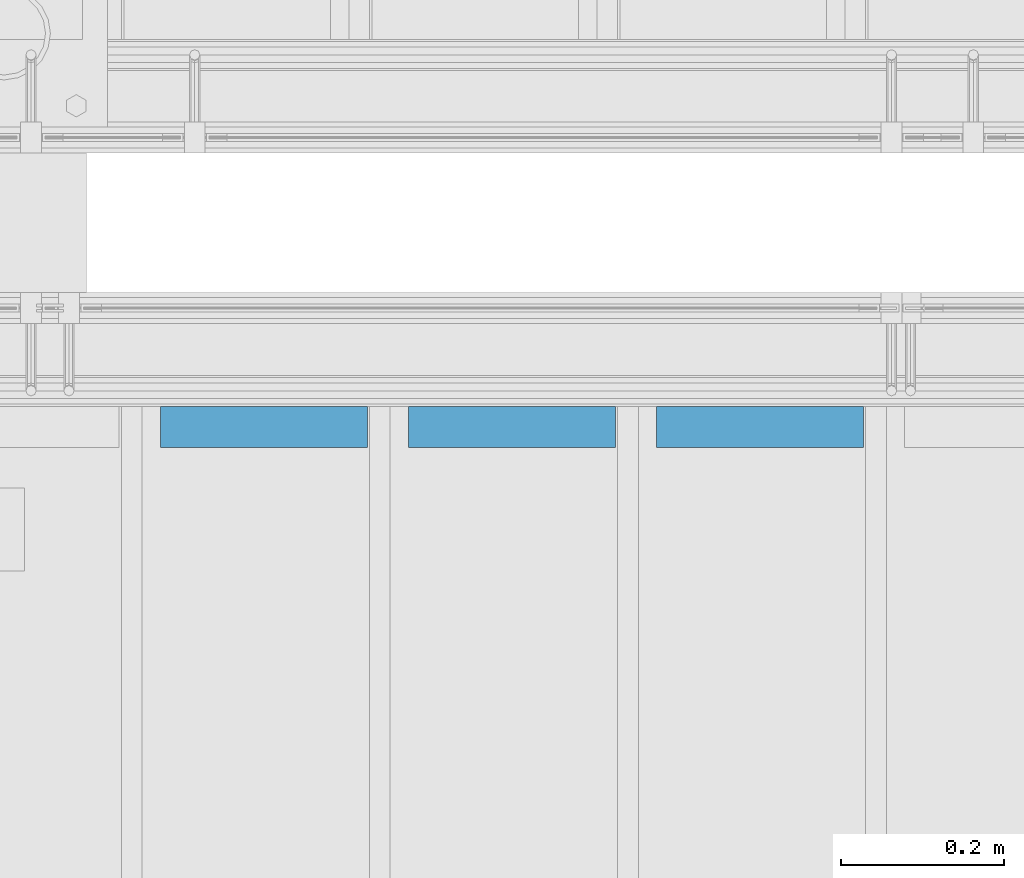
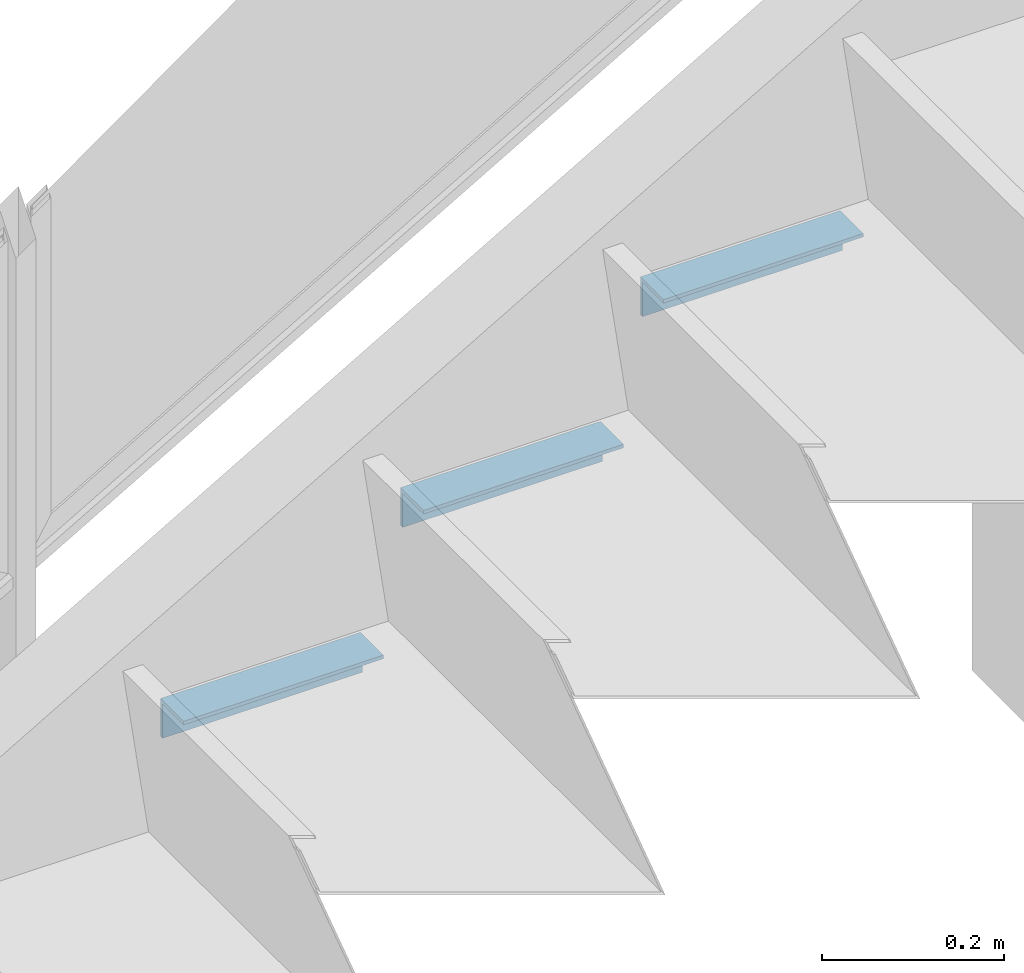
# One storey, part 916 of 1179: 3 beams, 1 element without a shape of its own.
"""IFC2X3 building model written with IfcOpenShell, lengths in millimetres."""

from ifc_helpers import new_model, si_unit, frame, origin_with_axes, place, context, subcontext, project, spatial, faceted_brep, material, type_object, element, aggregate, save


model = new_model("IFC2X3")

# Units and contexts
model_context = context("Model", 3, precision=1e-05, world=origin_with_axes())
body_context = subcontext(model_context, "Body", "Model", "MODEL_VIEW")
ifc_project = project(units=[si_unit("LENGTHUNIT", "METRE", prefix="MILLI"), si_unit("AREAUNIT", "SQUARE_METRE"), si_unit("VOLUMEUNIT", "CUBIC_METRE"), si_unit("MASSUNIT", "GRAM", prefix="KILO"), si_unit("TIMEUNIT", "SECOND"), si_unit("PLANEANGLEUNIT", "RADIAN"), si_unit("SOLIDANGLEUNIT", "STERADIAN"), si_unit("THERMODYNAMICTEMPERATUREUNIT", "DEGREE_CELSIUS"), si_unit("LUMINOUSINTENSITYUNIT", "LUMEN")], contexts=[model_context])

# Site, building, storey
site_placement = place(None, origin_with_axes())
site = spatial("IfcSite", under=ifc_project, at=site_placement, CompositionType="ELEMENT")
building_placement = place(site_placement, origin_with_axes())
building = spatial("IfcBuilding", under=site, at=building_placement, Name="Undefined", CompositionType="ELEMENT")
storey_placement = place(building_placement, origin_with_axes())
storey = spatial("IfcBuildingStorey", under=building, at=storey_placement, Name="Undefined", CompositionType="ELEMENT", Elevation=0.0)

# Assembly, beams
assembly_placement = place(storey_placement, origin_with_axes())
assembly = element("IfcElementAssembly", 1, at=assembly_placement, inside=storey, Name="STAIR", AssemblyPlace="NOTDEFINED", PredefinedType="RIGID_FRAME")
ifc_material = material(Name="STEEL/A36")
beam_type = type_object("IfcBeamType", Name="L2X2X3/16", PredefinedType="NOTDEFINED")
beam_1_placement = place(assembly_placement, frame((21377.6678271597, 39325.5499999974, 1156.55988296315), z_axis=(0.0, -1.0, 0.0), x_axis=(1.0, 0.0, 0.0)))
beam_1 = element("IfcBeam", 2, at=beam_1_placement, type_object=beam_type, material=ifc_material, Name="ANGLE", ObjectType="L2X2X3/16", context=body_context, shape_type="Brep", body=[
    faceted_brep([(0.0, 25.3999999999996, -25.4000000000015), (0.0, 25.3999999999996, 25.4000000000015), (254.0, 25.3999999999996, 25.4000000000001), (254.0, 25.3999999999996, -25.4000000000001), (0.0, 20.6374999999998, 25.4000000000015), (254.0, 20.6374999999998, 25.4000000000001), (0.0, 20.6374999999998, -20.6374999999971), (254.0, 20.6374999999998, -20.6374999999998), (0.0, -25.3999999999996, -20.6374999999971), (254.0, -25.3999999999996, -20.6374999999998), (0.0, -25.3999999999996, -25.4000000000015), (254.0, -25.3999999999996, -25.4000000000001)], [[[0, 1, 2, 3]], [[1, 4, 5, 2]], [[4, 6, 7, 5]], [[6, 8, 9, 7]], [[8, 10, 11, 9]], [[10, 0, 3, 11]], [[5, 7, 9, 11, 3, 2]], [[10, 8, 6, 4, 1, 0]]]),
])
beam_2_placement = place(assembly_placement, frame((21072.8678271329, 39325.5499999986, 980.082799683951), z_axis=(0.0, -1.0, 0.0), x_axis=(1.0, 0.0, 0.0)))
beam_2 = element("IfcBeam", 3, at=beam_2_placement, type_object=beam_type, material=ifc_material, Name="ANGLE", ObjectType="L2X2X3/16", context=body_context, shape_type="Brep", body=[
    faceted_brep([(0.0, 25.3999999999996, -25.4000000000015), (0.0, 25.3999999999996, 25.4000000000015), (254.0, 25.3999999999996, 25.4000000000001), (254.0, 25.3999999999996, -25.4000000000001), (0.0, 20.6374999999998, 25.4000000000015), (254.0, 20.6374999999998, 25.4000000000001), (0.0, 20.6374999999998, -20.6374999999971), (254.0, 20.6374999999998, -20.6374999999998), (0.0, -25.3999999999996, -20.6374999999971), (254.0, -25.3999999999996, -20.6374999999998), (0.0, -25.3999999999996, -25.4000000000015), (254.0, -25.3999999999996, -25.4000000000001)], [[[0, 1, 2, 3]], [[1, 4, 5, 2]], [[4, 6, 7, 5]], [[6, 8, 9, 7]], [[8, 10, 11, 9]], [[10, 0, 3, 11]], [[5, 7, 9, 11, 3, 2]], [[10, 8, 6, 4, 1, 0]]]),
])
beam_3_placement = place(assembly_placement, frame((20768.0678271062, 39325.5499999999, 803.605716404752), z_axis=(0.0, -1.0, 0.0), x_axis=(1.0, 0.0, 0.0)))
beam_3 = element("IfcBeam", 4, at=beam_3_placement, type_object=beam_type, material=ifc_material, Name="ANGLE", ObjectType="L2X2X3/16", context=body_context, shape_type="Brep", body=[
    faceted_brep([(0.0, 25.3999999999996, -25.4000000000015), (0.0, 25.3999999999996, 25.4000000000015), (254.0, 25.3999999999996, 25.4000000000001), (254.0, 25.3999999999996, -25.4000000000001), (0.0, 20.6374999999998, 25.4000000000015), (254.0, 20.6374999999998, 25.4000000000001), (0.0, 20.6374999999998, -20.6374999999971), (254.0, 20.6374999999998, -20.6374999999998), (0.0, -25.3999999999996, -20.6374999999971), (254.0, -25.3999999999996, -20.6374999999998), (0.0, -25.3999999999996, -25.4000000000015), (254.0, -25.3999999999996, -25.4000000000001)], [[[0, 1, 2, 3]], [[1, 4, 5, 2]], [[4, 6, 7, 5]], [[6, 8, 9, 7]], [[8, 10, 11, 9]], [[10, 0, 3, 11]], [[5, 7, 9, 11, 3, 2]], [[10, 8, 6, 4, 1, 0]]]),
])
aggregate(assembly, [beam_1, beam_2, beam_3])

save(model, "model.ifc")
